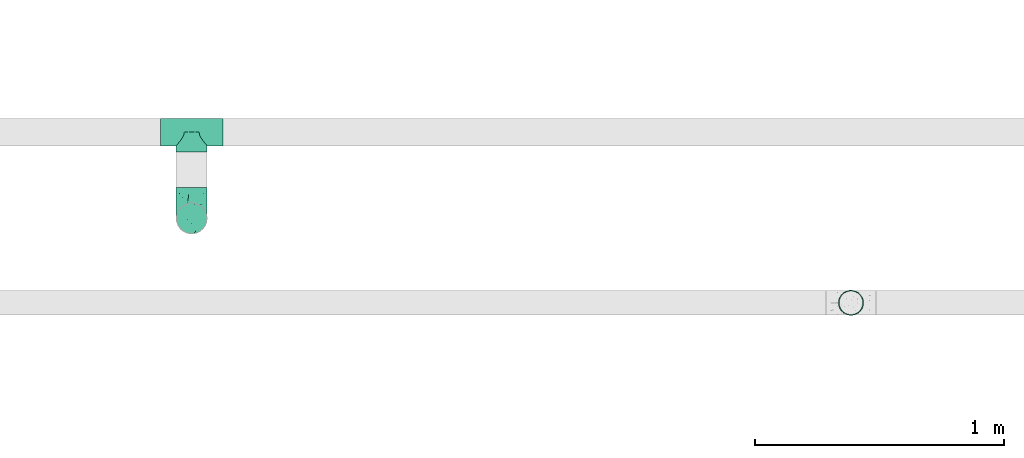
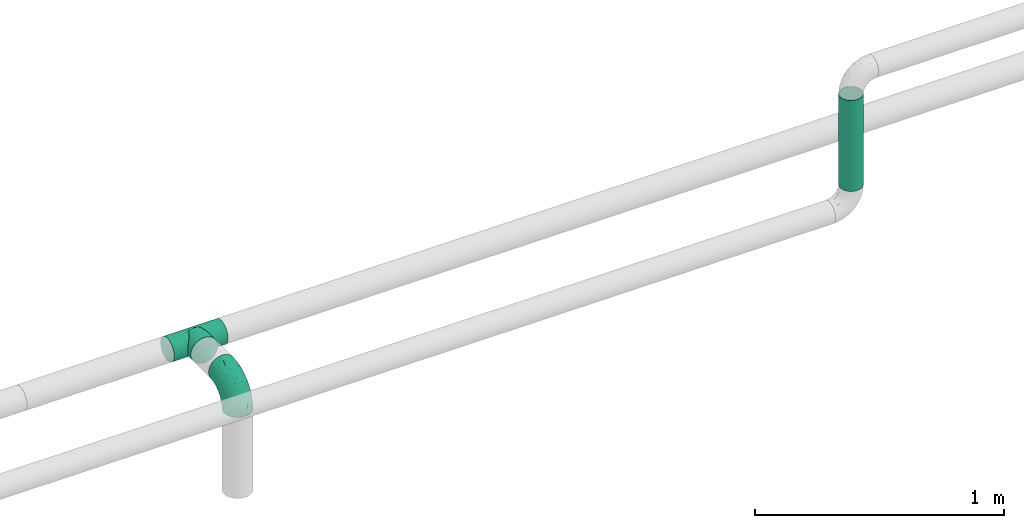
# One storey, part 15 of 91: 2 flow fittings, 1 flow segment.
"""IFC2X3 building model written with IfcOpenShell, lengths in millimetres."""

from ifc_helpers import new_model, entity, si_unit, converted_unit, derived_unit, direction, frame, origin_with_axes, origin_2d_with_axis, place, context, subcontext, project, spatial, hollow_circle, extrude, open_shell, surface_model, source, transform, mapped, material, layer, layer_set, layer_usage, type_object, element, save


model = new_model("IFC2X3")

# Units and contexts
model_context = context("Model", 3, precision=1e-05, world=origin_with_axes(), true_north=direction((0.0, 1.0)))
body_context = subcontext(model_context, "Body", "Model", "MODEL_VIEW")
ifc_project = project(units=[si_unit("AREAUNIT", "SQUARE_METRE"), si_unit("VOLUMEUNIT", "CUBIC_METRE", prefix="DECI"), si_unit("TIMEUNIT", "SECOND"), si_unit("THERMODYNAMICTEMPERATUREUNIT", "DEGREE_CELSIUS"), si_unit("PRESSUREUNIT", "PASCAL"), si_unit("MASSUNIT", "GRAM", prefix="KILO"), si_unit("LENGTHUNIT", "METRE", prefix="MILLI"), si_unit("POWERUNIT", "WATT"), si_unit("ELECTRICCURRENTUNIT", "AMPERE"), si_unit("ELECTRICVOLTAGEUNIT", "VOLT"), derived_unit("VOLUMETRICFLOWRATEUNIT", [(si_unit("VOLUMEUNIT", "CUBIC_METRE", prefix="DECI"), 1), (si_unit("TIMEUNIT", "SECOND"), -1)]), derived_unit("LINEARVELOCITYUNIT", [(si_unit("LENGTHUNIT", "METRE"), 1), (si_unit("TIMEUNIT", "SECOND"), -1)]), derived_unit("MASSDENSITYUNIT", [(si_unit("MASSUNIT", "GRAM", prefix="KILO"), 1), (si_unit("VOLUMEUNIT", "CUBIC_METRE"), -1)]), converted_unit("PLANEANGLEUNIT", "DEGREE", entity("IfcRatioMeasure", 0.01745), si_unit("PLANEANGLEUNIT", "RADIAN"), dimensions=[0, 0, 0, 0, 0, 0, 0])], contexts=[model_context])

# Site, building, storey
site_placement = place(None, origin_with_axes())
site = spatial("IfcSite", under=ifc_project, at=site_placement, CompositionType="ELEMENT")
building_placement = place(site_placement, origin_with_axes())
building = spatial("IfcBuilding", under=site, at=building_placement, Name="mc-building", CompositionType="ELEMENT")
storey_placement = place(building_placement, frame((0.0, 0.0, 8700.0), z_axis=(0.0, 0.0, 1.0), x_axis=(1.0, 0.0, 0.0)))
storey = spatial("IfcBuildingStorey", under=building, at=storey_placement, CompositionType="ELEMENT", Elevation=8700.0)

# Flow fittings
duct_fitting_type_1 = type_object("IfcDuctFittingType", Name="BU", PredefinedType="BEND")
shared_shape_1 = source(origin_with_axes(), body_context, "Body", "SurfaceModel", [
    surface_model("IfcShellBasedSurfaceModel", [(-125.0, 0.0, -62.5), (-125.0, -16.17619, -60.37037), (-125.0, 16.17619, -60.37037), (-125.0, 60.37037, 16.17619), (-125.0, 31.25, -54.12659), (-125.0, 54.12659, -31.25), (-125.0, 44.19417, -44.19417), (-125.0, -62.5, 0.0), (-125.0, -60.37037, 16.17619), (-125.0, -44.19417, -44.19417), (-125.0, -31.25, -54.12659), (-125.0, -60.37037, -16.17619), (-125.0, -54.12659, -31.25), (-125.0, 60.37037, -16.17619), (-125.0, 54.12659, 31.25), (-125.0, 44.19417, 44.19417), (-125.0, 16.17619, 60.37037), (-125.0, 31.25, 54.12659), (-125.0, -16.17619, 60.37037), (-125.0, -54.12659, 31.25), (-125.0, -44.19417, 44.19417), (-125.0, -31.25, 54.12659), (-125.0, 0.0, 62.5), (-125.0, 62.5, 0.0), (-16.17619, 125.0, -60.37037), (-62.5, 125.0, 0.0), (0.0, 125.0, -62.5), (-31.25, 125.0, -54.12659), (-44.19417, 125.0, -44.19417), (-54.12659, 125.0, -31.25), (44.19417, 125.0, -44.19417), (60.37037, 125.0, 16.17619), (31.25, 125.0, -54.12659), (16.17619, 125.0, -60.37037), (54.12659, 125.0, -31.25), (60.37037, 125.0, -16.17619), (62.5, 125.0, 0.0), (-60.37037, 125.0, -16.17619), (-60.37037, 125.0, 16.17619), (-54.12659, 125.0, 31.25), (-44.19417, 125.0, 44.19417), (-31.25, 125.0, 54.12659), (0.0, 125.0, 62.5), (-16.17619, 125.0, 60.37037), (54.12659, 125.0, 31.25), (44.19417, 125.0, 44.19417), (31.25, 125.0, 54.12659), (16.17619, 125.0, 60.37037), (-72.97423, 55.32904, 49.58459), (-87.09148, 43.38651, 51.77259), (-68.69218, 37.01083, 59.02974), (-86.37288, 6.11794, 62.5), (-102.44946, 13.57266, 61.46748), (-89.31796, 30.42505, 57.74247), (-79.75876, 21.08139, 61.40263), (-85.85709, 61.60432, 36.83247), (-105.99571, 52.01835, 38.04759), (-109.23107, 25.15527, 57.74247), (-23.87288, 51.52684, 62.5), (-20.86657, 80.09577, 61.41459), (-36.41116, 67.77294, 59.36871), (-72.59833, 84.97566, 20.44471), (-84.84527, 71.68644, 22.63776), (-72.28039, 75.08953, 34.06229), (-113.17841, 59.9112, 21.05599), (-105.80839, 64.31191, 11.93589), (-111.60883, 65.16367, 0.0), (-60.71426, 105.22832, 23.91771), (-100.62332, 62.31546, 23.91771), (-13.4791, 102.54506, 61.48083), (-6.11794, 86.37288, 62.5), (-65.16367, 111.60883, 0.0), (-64.37068, 105.82697, 11.61464), (-51.52684, 23.87288, 62.5), (-50.69134, 50.69135, 59.24335), (-105.32369, 40.3031, 49.58458), (-25.28712, 108.41778, 57.74247), (-40.88389, 102.97269, 49.58458), (-49.66967, 79.07581, 50.53579), (-30.95126, 87.95323, 57.74247), (-65.09409, 90.12761, 28.38341), (-66.67939, 95.80824, 18.23245), (-94.24179, 68.59274, 14.67936), (-56.68565, 61.95245, 53.66363), (-84.74719, 75.95181, 10.86071), (-51.54332, 107.92365, 38.04759), (-67.25753, 101.08228, 0.0), (-58.54205, 89.35136, 38.04759), (-74.03168, 90.94406, 0.0), (-64.15138, 70.52814, 45.04029), (-101.08228, 67.25753, 0.0), (-80.80582, 80.80582, 0.0), (-90.94406, 74.03168, 0.0), (-107.87602, 51.55441, -38.04759), (-105.81087, 64.31979, -11.89334), (-113.23859, 59.9943, -20.79563), (-102.50484, 41.0078, -49.58458), (-90.90834, 52.91787, -43.09941), (-86.37288, 6.11794, -62.5), (-82.6746, 22.37103, -60.91508), (-51.52684, 23.87288, -62.5), (-24.90859, 74.00088, -61.20337), (-6.11794, 86.37288, -62.5), (-23.87288, 51.52684, -62.5), (-40.24859, 105.55983, -49.58458), (-103.52624, 12.53143, -61.61172), (-52.01835, 105.9957, -38.04759), (-102.84629, 26.37525, -57.74247), (-80.60061, 37.86129, -56.26993), (-89.23788, 71.99576, -13.34087), (-28.31259, 95.51825, -57.74247), (-100.89706, 62.20969, -23.91771), (-79.09001, 65.16893, -38.04759), (-83.36843, 70.98492, -26.07025), (-72.14843, 76.80808, -32.35146), (-64.31191, 105.80839, -11.93589), (-62.31546, 100.62332, -23.91771), (-61.48499, 86.19979, -36.72576), (-65.63586, 35.3365, -60.01002), (-59.9112, 113.17841, -21.05599), (-14.35128, 101.66255, -61.35337), (-39.16846, 75.52412, -56.86737), (-49.98148, 49.98148, -59.57135), (-74.75599, 82.48123, -20.09995), (-79.93714, 49.60562, -50.24944), (-65.30683, 59.08485, -51.03937), (-69.00621, 93.51335, -14.6428), (-48.12403, 84.36987, -49.58459), (-65.05902, 72.16091, -43.27513), (-91.99255, 60.8749, -33.31849), (-74.30538, -22.05025, -54.52849), (-83.27732, -57.79898, 0.0), (-93.43528, -58.70511, -11.68929), (-65.26967, -50.32842, -16.71444), (20.96007, 31.53005, -39.63719), (36.17209, 58.4237, -38.31102), (29.66468, 29.66696, -26.32537), (-59.46467, 5.17337, -61.41841), (9.88584, 35.44281, -50.43749), (-6.21876, 6.21876, -45.37394), (1.26602, -1.26602, -32.1996), (5.97284, -5.97284, -16.71444), (-29.66696, -29.66468, -26.32537), (-5.17337, 59.46467, -61.41841), (-25.56296, 25.56296, -60.51531), (-85.76554, -12.75621, -59.78088), (48.55289, 56.98302, -11.64673), (57.71969, 88.32124, -11.85826), (57.79898, 83.27732, 0.0), (-8.09566, -21.5934, 0.0), (-43.6468, -43.93166, 0.0), (-26.3245, -32.97333, -12.3928), (-83.98915, -46.13442, -36.15679), (-66.40639, -30.82245, -46.75569), (-31.53004, -20.96006, -39.63719), (-52.51367, -36.89027, -34.10077), (12.75621, 85.76554, -59.78088), (4.48155, 49.92421, -57.42403), (37.53998, 99.49287, -48.41169), (22.05025, 74.30538, -54.52849), (-15.22434, 15.22435, -54.69384), (-49.9242, -4.48154, -57.42403), (51.83554, 76.17092, -22.12398), (46.66757, 86.70304, -36.28653), (-35.4428, -9.88583, -50.43749), (21.5934, 8.09566, 0.0), (43.93166, 43.6468, 0.0), (32.97333, 26.3245, -12.3928), (-99.49287, -37.53998, -48.41169), (30.82245, 66.40639, -46.75569), (-56.98302, -48.55289, 11.64673), (-88.32124, -57.71969, 11.85826), (50.32842, 65.26967, 16.71444), (-76.17092, -51.83554, 22.12398), (-5.17337, 59.46467, 61.41841), (12.75621, 85.76554, 59.78088), (-85.76554, -12.75621, 59.78088), (-49.9242, -4.48154, 57.42403), (-59.46467, 5.17337, 61.41841), (-26.3245, -32.97333, 12.3928), (-35.4428, -9.88583, 50.43749), (-31.53004, -20.96006, 39.63719), (-6.21876, 6.21876, 45.37394), (32.97333, 26.3245, 12.3928), (5.97284, -5.97284, 16.71444), (-99.49287, -37.53998, 48.41169), (-86.70304, -46.66757, 36.28653), (9.88584, 35.44281, 50.43749), (20.96007, 31.53005, 39.63719), (-15.22434, 15.22435, 54.69384), (4.48155, 49.92421, 57.42403), (-74.30538, -22.05025, 54.52849), (-25.56296, 25.56296, 60.51531), (37.53998, 99.49287, 48.41169), (46.13442, 83.98915, 36.15679), (29.66468, 29.66696, 26.32537), (-29.66696, -29.66468, 26.32537), (1.26602, -1.26602, 32.1996), (58.70511, 93.43528, 11.68929), (30.82245, 66.40639, 46.75569), (36.89027, 52.51367, 34.10076), (22.05025, 74.30538, 54.52849), (-58.42369, -36.17209, 38.31102), (-66.40639, -30.82245, 46.75569)], [open_shell([[[0, 1, 2]], [[2, 3, 4]], [[5, 6, 3]], [[4, 3, 6]], [[2, 7, 8]], [[9, 7, 10]], [[1, 10, 7]], [[11, 7, 12]], [[9, 12, 7]], [[7, 2, 1]], [[5, 3, 13]], [[14, 3, 2]], [[15, 14, 2]], [[2, 16, 17]], [[17, 15, 2]], [[2, 18, 16]], [[2, 8, 19]], [[2, 19, 20]], [[20, 21, 2]], [[18, 2, 21]], [[18, 22, 16]], [[23, 13, 3]], [[24, 25, 26]], [[27, 25, 24]], [[25, 28, 29]], [[28, 25, 27]], [[30, 26, 31]], [[26, 32, 33]], [[26, 30, 32]], [[30, 31, 34]], [[34, 31, 35]], [[31, 36, 35]], [[29, 37, 25]], [[38, 39, 26]], [[39, 40, 26]], [[26, 41, 42]], [[41, 26, 40]], [[41, 43, 42]], [[44, 31, 26]], [[45, 44, 26]], [[26, 46, 45]], [[47, 46, 26]], [[47, 26, 42]], [[25, 38, 26]], [[48, 49, 50]], [[22, 51, 52]], [[53, 54, 50]], [[55, 56, 49]], [[56, 14, 15]], [[16, 57, 17]], [[58, 59, 60]], [[61, 62, 63]], [[3, 64, 65]], [[53, 52, 54]], [[3, 65, 66]], [[67, 39, 38]], [[56, 68, 64]], [[65, 64, 68]], [[69, 59, 70]], [[38, 71, 72]], [[73, 58, 74]], [[75, 49, 56]], [[76, 69, 43]], [[53, 57, 52]], [[77, 78, 79]], [[41, 76, 43]], [[43, 69, 42]], [[55, 68, 56]], [[15, 17, 75]], [[76, 77, 79]], [[80, 67, 81]], [[62, 82, 68]], [[60, 78, 83]], [[62, 84, 82]], [[85, 77, 40]], [[81, 67, 72]], [[86, 72, 71]], [[87, 85, 67]], [[61, 81, 88]], [[77, 41, 40]], [[78, 77, 87]], [[15, 75, 56]], [[83, 89, 48]], [[85, 40, 39]], [[62, 68, 55]], [[89, 87, 63]], [[83, 48, 50]], [[57, 75, 17]], [[49, 75, 53]], [[67, 85, 39]], [[87, 77, 85]], [[63, 62, 55]], [[89, 55, 48]], [[80, 63, 87]], [[66, 65, 90]], [[66, 23, 3]], [[84, 91, 92]], [[92, 90, 82]], [[65, 82, 90]], [[61, 84, 62]], [[92, 82, 84]], [[68, 82, 65]], [[3, 14, 64]], [[56, 64, 14]], [[38, 25, 71]], [[81, 72, 86]], [[38, 72, 67]], [[91, 61, 88]], [[80, 81, 61]], [[63, 80, 61]], [[67, 80, 87]], [[77, 76, 41]], [[79, 59, 69]], [[79, 69, 76]], [[42, 69, 70]], [[60, 59, 79]], [[58, 70, 59]], [[78, 60, 79]], [[58, 60, 74]], [[52, 57, 16]], [[75, 57, 53]], [[22, 52, 16]], [[52, 51, 54]], [[51, 73, 54]], [[50, 73, 74]], [[73, 50, 54]], [[50, 74, 83]], [[60, 83, 74]], [[89, 83, 78]], [[87, 89, 78]], [[55, 89, 63]], [[50, 49, 53]], [[55, 49, 48]], [[81, 86, 88]], [[91, 84, 61]], [[6, 5, 93]], [[90, 94, 66]], [[13, 94, 95]], [[96, 93, 97]], [[98, 99, 100]], [[96, 4, 6]], [[101, 102, 103]], [[28, 27, 104]], [[2, 105, 0]], [[104, 106, 28]], [[99, 105, 107]], [[108, 107, 96]], [[90, 109, 94]], [[107, 2, 4]], [[13, 66, 94]], [[27, 24, 110]], [[109, 111, 94]], [[112, 113, 114]], [[37, 115, 71]], [[116, 106, 117]], [[99, 118, 100]], [[116, 115, 119]], [[37, 119, 115]], [[24, 120, 110]], [[121, 110, 101]], [[119, 106, 116]], [[101, 110, 120]], [[122, 103, 100]], [[117, 123, 116]], [[124, 125, 108]], [[115, 116, 126]], [[106, 29, 28]], [[26, 102, 120]], [[127, 104, 110]], [[97, 124, 96]], [[125, 122, 118]], [[128, 127, 125]], [[96, 6, 93]], [[115, 126, 86]], [[117, 106, 127]], [[111, 113, 129]], [[95, 93, 5]], [[97, 129, 112]], [[110, 104, 27]], [[106, 104, 127]], [[96, 107, 4]], [[99, 107, 108]], [[99, 108, 118]], [[105, 99, 98]], [[112, 114, 128]], [[121, 125, 127]], [[13, 23, 66]], [[109, 90, 92]], [[94, 111, 95]], [[91, 123, 109]], [[129, 113, 112]], [[93, 95, 111]], [[5, 13, 95]], [[71, 115, 86]], [[71, 25, 37]], [[123, 91, 88]], [[126, 116, 123]], [[123, 88, 126]], [[86, 126, 88]], [[37, 29, 119]], [[106, 119, 29]], [[129, 93, 111]], [[124, 112, 125]], [[0, 105, 98]], [[107, 105, 2]], [[125, 118, 108]], [[100, 118, 122]], [[93, 129, 97]], [[113, 111, 109]], [[109, 123, 113]], [[114, 123, 117]], [[123, 114, 113]], [[128, 114, 117]], [[127, 128, 117]], [[112, 128, 125]], [[103, 122, 101]], [[110, 121, 127]], [[101, 122, 121]], [[125, 121, 122]], [[26, 120, 24]], [[101, 120, 102]], [[96, 124, 108]], [[92, 91, 109]], [[112, 124, 97]], [[10, 1, 130]], [[131, 132, 133]], [[134, 135, 136]], [[98, 100, 137]], [[138, 134, 139]], [[140, 141, 142]], [[143, 144, 103]], [[98, 145, 0]], [[146, 147, 148]], [[149, 150, 151]], [[7, 11, 132]], [[133, 12, 152]], [[153, 154, 155]], [[152, 12, 9]], [[156, 157, 143]], [[142, 151, 133]], [[155, 133, 152]], [[158, 159, 32]], [[136, 141, 140]], [[137, 145, 98]], [[103, 144, 100]], [[133, 132, 12]], [[160, 161, 144]], [[137, 144, 161]], [[160, 144, 157]], [[156, 26, 33]], [[130, 1, 145]], [[34, 162, 163]], [[164, 139, 154]], [[30, 158, 32]], [[160, 138, 139]], [[163, 30, 34]], [[156, 159, 157]], [[149, 141, 165]], [[146, 166, 167]], [[168, 9, 10]], [[36, 148, 147]], [[9, 168, 152]], [[150, 131, 133]], [[166, 146, 148]], [[166, 165, 167]], [[141, 136, 167]], [[160, 164, 161]], [[143, 103, 102]], [[151, 141, 149]], [[35, 162, 34]], [[135, 162, 136]], [[158, 163, 169]], [[144, 137, 100]], [[145, 137, 161]], [[145, 161, 130]], [[145, 1, 0]], [[102, 26, 156]], [[144, 143, 157]], [[102, 156, 143]], [[159, 33, 32]], [[141, 167, 165]], [[146, 136, 162]], [[133, 151, 150]], [[141, 151, 142]], [[164, 130, 161]], [[130, 153, 168]], [[159, 156, 33]], [[138, 159, 169]], [[138, 160, 157]], [[164, 160, 139]], [[154, 140, 142]], [[134, 140, 139]], [[159, 138, 157]], [[134, 136, 140]], [[138, 169, 134]], [[135, 134, 169]], [[139, 140, 154]], [[130, 164, 153]], [[155, 154, 142]], [[153, 164, 154]], [[136, 146, 167]], [[146, 162, 147]], [[162, 35, 147]], [[36, 147, 35]], [[130, 168, 10]], [[152, 168, 153]], [[163, 158, 30]], [[159, 158, 169]], [[7, 132, 131]], [[12, 132, 11]], [[169, 163, 135]], [[135, 163, 162]], [[133, 155, 142]], [[153, 155, 152]], [[150, 170, 131]], [[171, 7, 131]], [[166, 148, 172]], [[8, 173, 19]], [[174, 175, 70]], [[176, 177, 178]], [[149, 179, 150]], [[170, 150, 179]], [[180, 181, 182]], [[165, 183, 184]], [[20, 185, 21]], [[20, 19, 186]], [[187, 182, 188]], [[189, 187, 190]], [[185, 191, 21]], [[22, 18, 176]], [[190, 192, 189]], [[189, 180, 182]], [[178, 73, 51]], [[19, 173, 186]], [[149, 165, 184]], [[45, 193, 194]], [[191, 177, 176]], [[165, 166, 183]], [[195, 183, 172]], [[196, 184, 197]], [[194, 44, 45]], [[198, 36, 31]], [[199, 188, 200]], [[172, 198, 44]], [[193, 45, 46]], [[194, 200, 172]], [[175, 42, 70]], [[192, 58, 73]], [[170, 171, 131]], [[189, 192, 177]], [[70, 58, 174]], [[190, 174, 192]], [[179, 184, 196]], [[197, 184, 195]], [[47, 201, 46]], [[181, 202, 196]], [[148, 198, 172]], [[201, 47, 175]], [[172, 44, 194]], [[178, 192, 73]], [[202, 173, 196]], [[185, 186, 203]], [[192, 174, 58]], [[175, 174, 190]], [[175, 190, 201]], [[175, 47, 42]], [[51, 22, 176]], [[192, 178, 177]], [[51, 176, 178]], [[191, 18, 21]], [[184, 179, 149]], [[170, 196, 173]], [[172, 183, 166]], [[184, 183, 195]], [[187, 201, 190]], [[201, 199, 193]], [[191, 176, 18]], [[180, 191, 203]], [[180, 189, 177]], [[187, 189, 182]], [[188, 197, 195]], [[181, 197, 182]], [[191, 180, 177]], [[181, 196, 197]], [[180, 203, 181]], [[202, 181, 203]], [[182, 197, 188]], [[201, 187, 199]], [[200, 188, 195]], [[199, 187, 188]], [[196, 170, 179]], [[170, 173, 171]], [[173, 8, 171]], [[7, 171, 8]], [[201, 193, 46]], [[194, 193, 199]], [[186, 185, 20]], [[191, 185, 203]], [[36, 198, 148]], [[44, 198, 31]], [[203, 186, 202]], [[202, 186, 173]], [[172, 200, 195]], [[199, 200, 194]]])]),
])
flow_fitting_1_placement = place(storey_placement, frame((3422.17999, 6304.03427, 415.0), z_axis=(-1.0, 0.0, 0.0), x_axis=(0.0, 0.0, 1.0)))
element("IfcFlowFitting", 1, at=flow_fitting_1_placement, inside=storey, type_object=duct_fitting_type_1, Name="BU", context=body_context, shape_type="MappedRepresentation", body=[
    mapped(shared_shape_1, transform((0.0, 0.0, 0.0), scale=1.0)),
])
duct_fitting_type_2 = type_object("IfcDuctFittingType", PredefinedType="JUNCTION")
shared_shape_2 = source(origin_with_axes(), body_context, "Body", "SurfaceModel", [
    surface_model("IfcShellBasedSurfaceModel", [(0.0, -80.0, -62.5), (16.17619, -80.0, -60.37037), (-16.17619, -80.0, -60.37037), (-60.37037, -80.0, 16.17619), (-31.25, -80.0, -54.12659), (-44.19417, -80.0, -44.19417), (-54.12659, -80.0, -31.25), (62.5, -80.0, 0.0), (60.37037, -80.0, 16.17619), (44.19417, -80.0, -44.19417), (31.25, -80.0, -54.12659), (60.37037, -80.0, -16.17619), (54.12659, -80.0, -31.25), (-60.37037, -80.0, -16.17619), (-54.12659, -80.0, 31.25), (-44.19417, -80.0, 44.19417), (-31.25, -80.0, 54.12659), (-16.17619, -80.0, 60.37037), (16.17619, -80.0, 60.37037), (54.12659, -80.0, 31.25), (44.19417, -80.0, 44.19417), (31.25, -80.0, 54.12659), (0.0, -80.0, 62.5), (-62.5, -80.0, 0.0), (0.0, 0.0, 62.5), (-15.31424, 0.0, 60.59475), (-29.68586, 0.0, 55.0), (-31.79332, -11.38268, 53.80924), (-62.5, -55.0, 0.0), (-61.43518, -80.0, 8.0881), (-61.42389, -53.77401, 11.548), (-36.65815, -21.50744, 50.62045), (-42.49909, -30.41254, 45.8266), (-48.42243, -38.25549, 39.51605), (-53.88367, -44.96887, 31.66703), (-58.39386, -50.28512, 22.28019), (-61.42389, -53.77401, -11.548), (-58.39386, -50.28512, -22.28019), (-53.88367, -44.96887, -31.66703), (-48.42243, -38.25549, -39.51605), (-61.43518, -80.0, -8.0881), (-42.49909, -30.41254, -45.8266), (-31.79332, -11.38268, -53.80924), (-29.68586, 0.0, -55.0), (-15.31424, 0.0, -60.59475), (0.0, 0.0, -62.5), (-36.65815, -21.50744, -50.62045), (15.31424, 0.0, -60.59475), (29.68586, 0.0, -55.0), (31.79332, -11.38268, -53.80924), (62.5, -55.0, 0.0), (61.43518, -80.0, -8.0881), (61.42389, -53.77401, -11.548), (36.65815, -21.50744, -50.62045), (42.49909, -30.41254, -45.8266), (48.42243, -38.25549, -39.51605), (53.88367, -44.96887, -31.66703), (58.39386, -50.28512, -22.28019), (61.42389, -53.77401, 11.548), (58.39386, -50.28512, 22.28019), (53.88367, -44.96887, 31.66703), (48.42243, -38.25549, 39.51605), (61.43518, -80.0, 8.0881), (42.49909, -30.41254, 45.8266), (31.79332, -11.38268, 53.80924), (29.68586, 0.0, 55.0), (15.31424, 0.0, 60.59475), (36.65815, -21.50744, 50.62045), (-125.0, 0.0, -55.0), (-125.0, -14.23505, -53.12592), (-125.0, 14.23505, -53.12592), (-125.0, 53.12592, 14.23505), (-125.0, 27.5, -47.63139), (-125.0, 47.63139, -27.5), (-125.0, 38.89087, -38.89087), (-125.0, -55.0, 0.0), (-125.0, -53.12592, 14.23505), (-125.0, -38.89087, -38.89087), (-125.0, -27.5, -47.63139), (-125.0, -53.12592, -14.23505), (-125.0, -47.63139, -27.5), (-125.0, 53.12592, -14.23505), (-125.0, 47.63139, 27.5), (-125.0, 38.89087, 38.89087), (-125.0, -14.23505, 53.12592), (-125.0, 27.5, 47.63139), (-125.0, 14.23505, 53.12592), (-125.0, -47.63139, 27.5), (-125.0, -38.89087, 38.89087), (-125.0, -27.5, 47.63139), (-125.0, 0.0, 55.0), (-125.0, 55.0, 0.0), (125.0, 55.0, 0.0), (125.0, 0.0, -55.0), (125.0, 14.23505, -53.12592), (125.0, 27.5, -47.63139), (125.0, 38.89087, -38.89087), (125.0, 47.63139, -27.5), (125.0, -38.89087, -38.89087), (125.0, -53.12592, 14.23505), (125.0, -27.5, -47.63139), (125.0, -14.23505, -53.12592), (125.0, -47.63139, -27.5), (125.0, -53.12592, -14.23505), (125.0, -55.0, 0.0), (125.0, 53.12592, -14.23505), (125.0, 53.12592, 14.23505), (125.0, 47.63139, 27.5), (125.0, 38.89087, 38.89087), (125.0, 0.0, 55.0), (125.0, 27.5, 47.63139), (125.0, 14.23505, 53.12592), (125.0, -47.63139, 27.5), (125.0, -38.89087, 38.89087), (125.0, -27.5, 47.63139), (125.0, -14.23505, 53.12592)], [open_shell([[[0, 1, 2]], [[2, 3, 4]], [[5, 3, 6]], [[4, 3, 5]], [[2, 7, 8]], [[9, 7, 10]], [[1, 10, 7]], [[11, 7, 12]], [[9, 12, 7]], [[7, 2, 1]], [[13, 6, 3]], [[2, 14, 3]], [[2, 15, 14]], [[16, 2, 17]], [[16, 15, 2]], [[17, 2, 18]], [[19, 20, 2]], [[19, 2, 8]], [[20, 21, 2]], [[2, 21, 18]], [[18, 22, 17]], [[23, 13, 3]], [[22, 24, 25]], [[26, 27, 25]], [[28, 29, 30]], [[17, 25, 27]], [[22, 25, 17]], [[16, 31, 32]], [[16, 17, 27]], [[16, 32, 15]], [[31, 16, 27]], [[33, 34, 14]], [[35, 30, 3]], [[34, 35, 14]], [[15, 33, 14]], [[30, 29, 3]], [[3, 14, 35]], [[29, 28, 23]], [[33, 15, 32]], [[36, 37, 13]], [[38, 39, 6]], [[37, 38, 6]], [[36, 40, 28]], [[28, 40, 23]], [[13, 37, 6]], [[39, 5, 6]], [[39, 41, 5]], [[42, 43, 44]], [[36, 13, 40]], [[42, 44, 2]], [[0, 44, 45]], [[41, 46, 4]], [[42, 4, 46]], [[42, 2, 4]], [[44, 0, 2]], [[41, 4, 5]], [[0, 45, 47]], [[48, 49, 47]], [[50, 51, 52]], [[1, 47, 49]], [[0, 47, 1]], [[10, 53, 54]], [[10, 1, 49]], [[10, 54, 9]], [[53, 10, 49]], [[55, 56, 12]], [[57, 52, 11]], [[56, 57, 12]], [[9, 55, 12]], [[52, 51, 11]], [[11, 12, 57]], [[51, 50, 7]], [[55, 9, 54]], [[58, 59, 8]], [[60, 61, 19]], [[59, 60, 19]], [[58, 62, 50]], [[7, 50, 62]], [[59, 19, 8]], [[61, 20, 19]], [[61, 63, 20]], [[64, 65, 66]], [[58, 8, 62]], [[64, 66, 18]], [[22, 66, 24]], [[63, 67, 21]], [[64, 21, 67]], [[64, 18, 21]], [[66, 22, 18]], [[63, 21, 20]], [[68, 69, 70]], [[70, 71, 72]], [[73, 74, 71]], [[72, 71, 74]], [[70, 75, 76]], [[77, 75, 78]], [[69, 78, 75]], [[79, 75, 80]], [[77, 80, 75]], [[75, 70, 69]], [[73, 71, 81]], [[70, 82, 71]], [[70, 83, 82]], [[70, 84, 85]], [[85, 83, 70]], [[84, 86, 85]], [[70, 87, 88]], [[87, 70, 76]], [[88, 89, 70]], [[70, 89, 84]], [[84, 90, 86]], [[91, 81, 71]], [[92, 93, 94]], [[95, 92, 94]], [[92, 96, 97]], [[96, 92, 95]], [[98, 93, 99]], [[93, 98, 100]], [[100, 101, 93]], [[98, 99, 102]], [[102, 99, 103]], [[104, 103, 99]], [[105, 92, 97]], [[106, 107, 93]], [[93, 107, 108]], [[109, 93, 110]], [[93, 108, 110]], [[109, 110, 111]], [[112, 99, 93]], [[113, 112, 93]], [[114, 113, 93]], [[115, 114, 93]], [[115, 93, 109]], [[92, 106, 93]], [[65, 109, 111]], [[65, 111, 86]], [[85, 111, 110]], [[90, 26, 86]], [[86, 26, 65]], [[111, 85, 86]], [[110, 83, 85]], [[82, 108, 107]], [[71, 107, 106]], [[91, 106, 92]], [[83, 108, 82]], [[82, 107, 71]], [[106, 91, 71]], [[108, 83, 110]], [[81, 92, 105]], [[73, 105, 97]], [[74, 97, 96]], [[91, 92, 81]], [[81, 105, 73]], [[97, 74, 73]], [[96, 72, 74]], [[70, 95, 94]], [[93, 48, 94]], [[43, 94, 48]], [[72, 95, 70]], [[43, 68, 70]], [[94, 43, 70]], [[95, 72, 96]], [[68, 43, 42]], [[69, 42, 46]], [[78, 46, 41]], [[68, 42, 69]], [[77, 41, 39]], [[78, 69, 46]], [[41, 77, 78]], [[38, 37, 80]], [[36, 28, 75]], [[37, 36, 79]], [[77, 38, 80]], [[80, 37, 79]], [[36, 75, 79]], [[38, 77, 39]], [[49, 93, 101]], [[101, 100, 53]], [[98, 54, 100]], [[98, 55, 54]], [[48, 93, 49]], [[49, 101, 53]], [[100, 54, 53]], [[56, 98, 102]], [[57, 102, 103]], [[52, 103, 104]], [[57, 56, 102]], [[50, 52, 104]], [[57, 103, 52]], [[98, 56, 55]], [[28, 30, 75]], [[35, 34, 87]], [[30, 35, 76]], [[75, 30, 76]], [[76, 35, 87]], [[34, 88, 87]], [[34, 33, 88]], [[89, 32, 31]], [[31, 27, 84]], [[26, 90, 27]], [[32, 88, 33]], [[32, 89, 88]], [[89, 31, 84]], [[27, 90, 84]], [[58, 104, 99]], [[59, 99, 112]], [[60, 112, 113]], [[58, 50, 104]], [[60, 59, 112]], [[58, 99, 59]], [[113, 61, 60]], [[61, 113, 63]], [[63, 113, 114]], [[67, 114, 115]], [[64, 115, 109]], [[63, 114, 67]], [[64, 67, 115]], [[65, 64, 109]], [[65, 26, 24]], [[65, 24, 66]], [[24, 26, 25]], [[47, 45, 48]], [[43, 48, 45]], [[43, 45, 44]]])]),
])
flow_fitting_2_placement = place(storey_placement, frame((3422.17999, 6650.69751, 415.0), z_axis=(0.0, 0.0, 1.0), x_axis=(1.0, 0.0, 0.0)))
element("IfcFlowFitting", 2, at=flow_fitting_2_placement, inside=storey, type_object=duct_fitting_type_2, context=body_context, shape_type="MappedRepresentation", body=[
    mapped(shared_shape_2, transform((0.0, 0.0, 0.0), scale=1.0)),
])

# Flow segment
ifc_material = material(Name="FZ1")
ifc_layer = layer(ifc_material, 0.0)
ifc_layer_set = layer_set([ifc_layer], Name="FZ1")
ifc_layer_usage = layer_usage(ifc_layer_set, "AXIS1", "POSITIVE", 0.0)
duct_segment_type = type_object("IfcDuctSegmentType", Name="Safe", PredefinedType="RIGIDSEGMENT")
shared_shape_3 = source(origin_with_axes(), body_context, "Body", "SweptSolid", [
    extrude(hollow_circle(Radius=50.0, WallThickness=2.0, at=origin_2d_with_axis()), frame((0.0, 0.0, 0.0), z_axis=(1.0, 0.0, 0.0), x_axis=(0.0, 1.0, 0.0)), (0.0, 0.0, 1.0), 446.6),
])
flow_segment_placement = place(storey_placement, frame((6072.12654, 5964.82923, 1114.3), z_axis=(0.0, 1.0, 0.0), x_axis=(0.0, 0.0, -1.0)))
element("IfcFlowSegment", 3, at=flow_segment_placement, inside=storey, type_object=duct_segment_type, material=ifc_layer_usage, Name="Safe", context=body_context, shape_type="MappedRepresentation", body=[
    mapped(shared_shape_3, transform((0.0, 0.0, 0.0), scale=1.0)),
])

save(model, "model.ifc")
